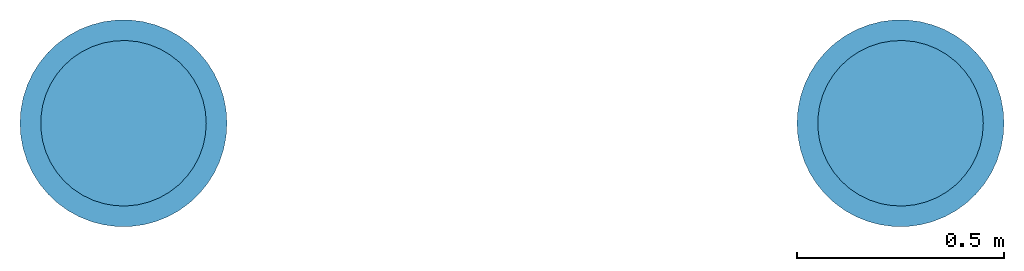
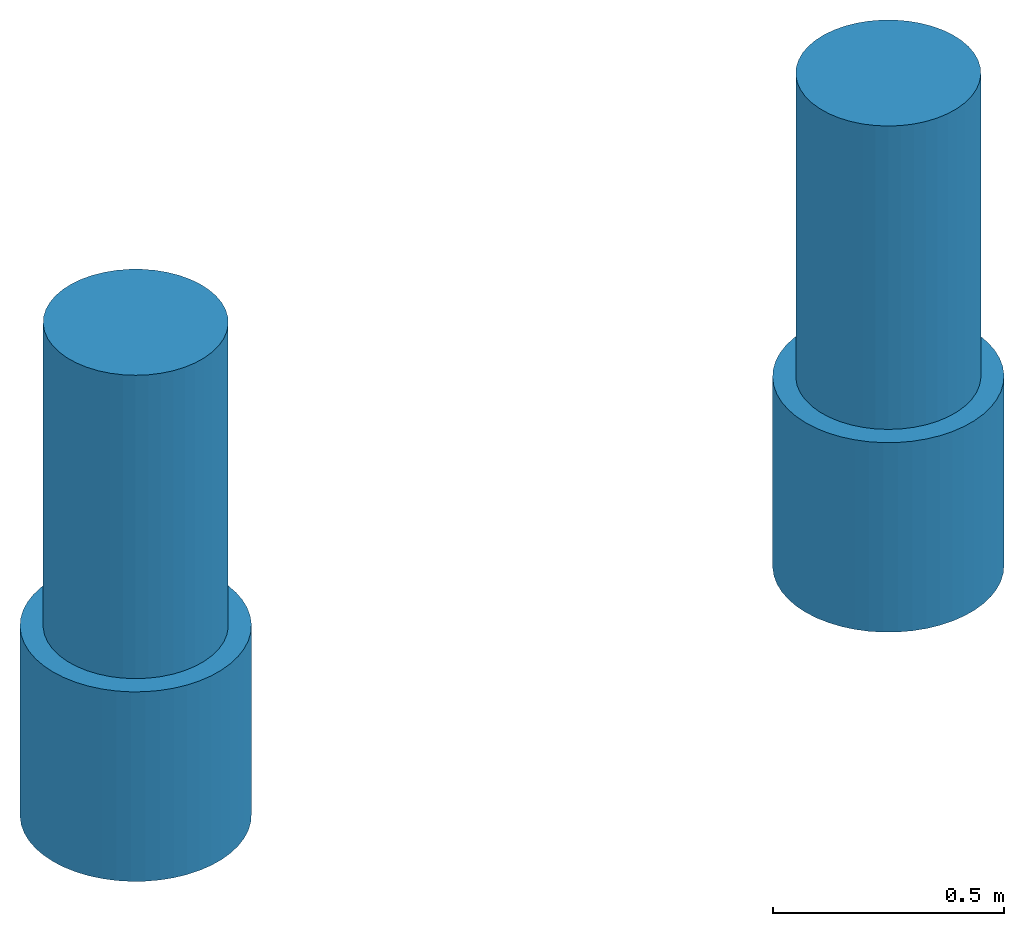
# One storey: 4 building element parts, 2 elements without a shape of their own.
"""IFC4 building model written with IfcOpenShell, lengths in metres."""

from ifc_helpers import new_model, si_unit, frame, origin_with_axes, origin_2d, origin_2d_with_axis, place, context, subcontext, project, spatial, circle_curve, outline, extrude, type_object, element, aggregate, save


model = new_model("IFC4")

# Units and contexts
model_context = context("Model", 3, precision=1e-05, world=origin_with_axes())
plan_context = context("Plan", 2, precision=1e-05, world=origin_2d_with_axis())
body_context = subcontext(model_context, "Body", "Model", "MODEL_VIEW")
ifc_project = project(units=[si_unit("AREAUNIT", "SQUARE_METRE"), si_unit("VOLUMEUNIT", "CUBIC_METRE"), si_unit("LENGTHUNIT", "METRE")], contexts=[model_context, plan_context])

# Site, building, storey
site_placement = place(None, origin_with_axes())
site = spatial("IfcSite", under=ifc_project, at=site_placement)
building_placement = place(site_placement, origin_with_axes())
building = spatial("IfcBuilding", under=site, at=building_placement, Name="Building")
storey_placement = place(building_placement, origin_with_axes())
storey = spatial("IfcBuildingStorey", under=building, at=storey_placement, Name="Storey")

# Column, building element parts
column_type = type_object("IfcColumnType", PredefinedType="COLUMN")
column_1_placement = place(storey_placement, frame((3.48845839500427, 4.09408617019653, 0.0), z_axis=(0.0, 0.0, 1.0), x_axis=(1.0, 0.0, 0.0)))
column_1 = element("IfcColumn", 1, at=column_1_placement, inside=storey, type_object=column_type, Name="Column")
building_element_part_1_placement = place(None, frame((3.48845839500427, 4.09408617019653, 0.0), z_axis=(0.0, 0.0, 1.0), x_axis=(1.0, 0.0, 0.0)))
building_element_part_1 = element("IfcBuildingElementPart", 2, at=building_element_part_1_placement, Name="BLOC", PredefinedType="NOTDEFINED", context=body_context, shape_type="SweptSolid", body=[
    extrude(outline(circle_curve(origin_2d(), 0.25)), origin_with_axes(), (0.0, 0.0, 1.0), 0.5),
])
building_element_part_2_placement = place(None, frame((3.48845839500427, 4.09408617019653, 0.5), z_axis=(0.0, 0.0, 1.0), x_axis=(1.0, 0.0, 0.0)))
building_element_part_2 = element("IfcBuildingElementPart", 3, at=building_element_part_2_placement, Name="BLOC", PredefinedType="NOTDEFINED", context=body_context, shape_type="SweptSolid", body=[
    extrude(outline(circle_curve(origin_2d(), 0.200000007078051)), None, (0.0, 0.0, 1.0), 0.800000011920929),
])
aggregate(column_1, [building_element_part_1, building_element_part_2])

column_2_placement = place(storey_placement, frame((5.36585378646851, 4.09408617019653, 0.0), z_axis=(0.0, 0.0, 1.0), x_axis=(1.0, 0.0, 0.0)))
column_2 = element("IfcColumn", 4, at=column_2_placement, inside=storey, type_object=column_type, Name="Column")
building_element_part_3_placement = place(column_2_placement, frame((0.0, 0.0, 0.5), z_axis=(0.0, 0.0, 1.0), x_axis=(1.0, 0.0, 0.0)))
building_element_part_3 = element("IfcBuildingElementPart", 5, at=building_element_part_3_placement, Name="BLOC", PredefinedType="NOTDEFINED", context=body_context, shape_type="SweptSolid", body=[
    extrude(outline(circle_curve(origin_2d(), 0.200000007078051)), None, (0.0, 0.0, 1.0), 0.800000011920929),
])
building_element_part_4_placement = place(column_2_placement, origin_with_axes())
building_element_part_4 = element("IfcBuildingElementPart", 6, at=building_element_part_4_placement, Name="BLOC", PredefinedType="NOTDEFINED", context=body_context, shape_type="SweptSolid", body=[
    extrude(outline(circle_curve(origin_2d(), 0.25)), origin_with_axes(), (0.0, 0.0, 1.0), 0.5),
])
aggregate(column_2, [building_element_part_3, building_element_part_4])

save(model, "model.ifc")
